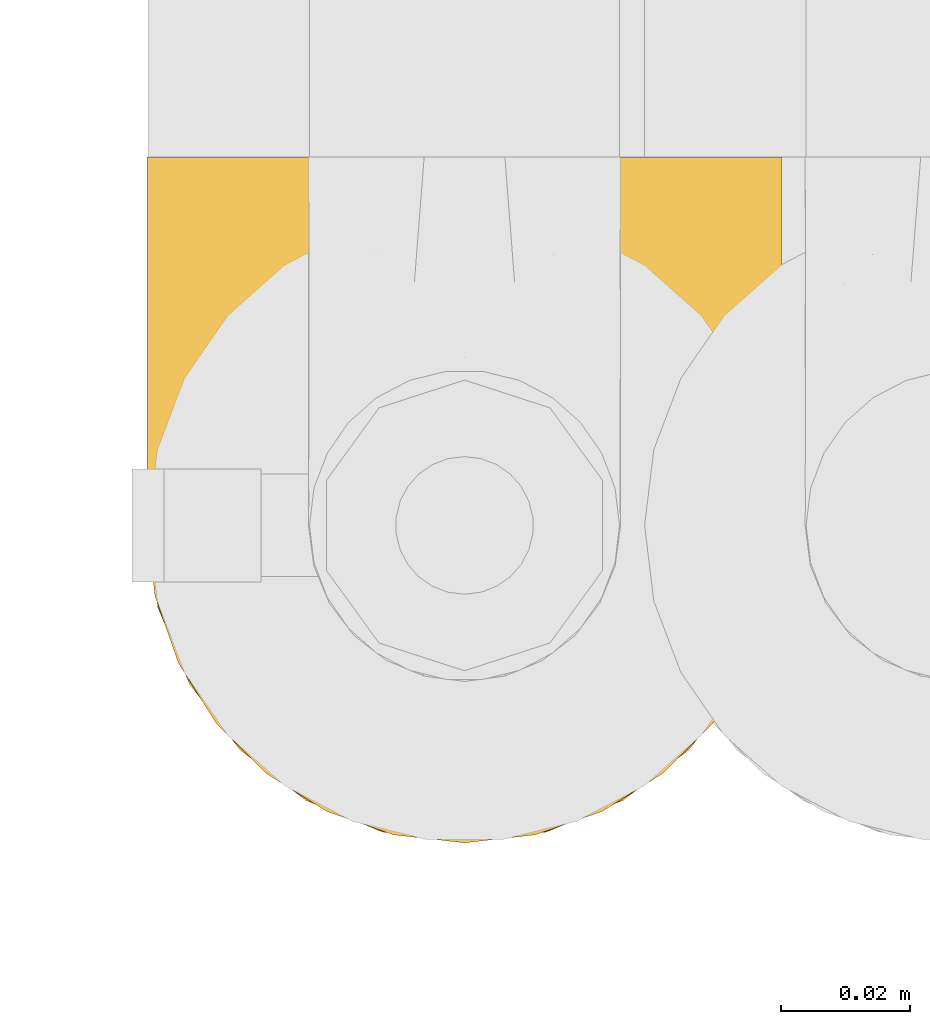
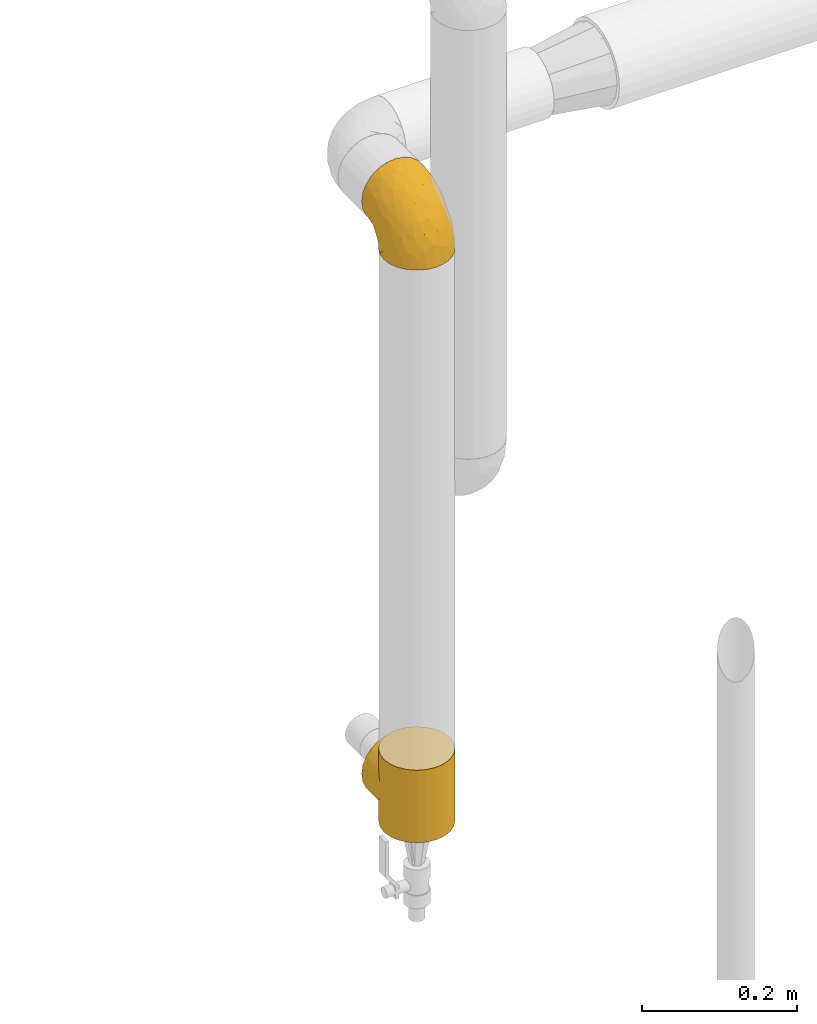
# One storey, part 410 of 827: 2 coverings.
"""IFC2X3 building model written with IfcOpenShell, lengths in millimetres."""

from ifc_helpers import new_model, entity, si_unit, converted_unit, derived_unit, direction, frame, origin, place, context, subcontext, project, spatial, faceted_brep, element, save


model = new_model("IFC2X3")

# Units and contexts
model_context = context("Model", 3, precision=0.01, world=origin(), true_north=direction((6.12303176911189e-17, 1.0)))
body_context = subcontext(model_context, "Body", "Model", "MODEL_VIEW")
ifc_project = project(units=[si_unit("LENGTHUNIT", "METRE", prefix="MILLI"), si_unit("AREAUNIT", "SQUARE_METRE"), si_unit("VOLUMEUNIT", "CUBIC_METRE"), converted_unit("PLANEANGLEUNIT", "DEGREE", entity("IfcRatioMeasure", 0.0174532925199433), si_unit("PLANEANGLEUNIT", "RADIAN"), dimensions=[0, 0, 0, 0, 0, 0, 0]), si_unit("MASSUNIT", "GRAM", prefix="KILO"), derived_unit("MASSDENSITYUNIT", [(si_unit("MASSUNIT", "GRAM", prefix="KILO"), 1), (si_unit("LENGTHUNIT", "METRE"), -3)]), derived_unit("MOMENTOFINERTIAUNIT", [(si_unit("LENGTHUNIT", "METRE"), 4)]), si_unit("TIMEUNIT", "SECOND"), si_unit("FREQUENCYUNIT", "HERTZ"), si_unit("THERMODYNAMICTEMPERATUREUNIT", "DEGREE_CELSIUS"), derived_unit("THERMALTRANSMITTANCEUNIT", [(si_unit("MASSUNIT", "GRAM", prefix="KILO"), 1), (si_unit("THERMODYNAMICTEMPERATUREUNIT", "KELVIN"), -1), (si_unit("TIMEUNIT", "SECOND"), -3)]), derived_unit("VOLUMETRICFLOWRATEUNIT", [(si_unit("LENGTHUNIT", "METRE"), 3), (si_unit("TIMEUNIT", "SECOND"), -1)]), derived_unit("MASSFLOWRATEUNIT", [(si_unit("MASSUNIT", "GRAM", prefix="KILO"), 1), (si_unit("TIMEUNIT", "SECOND"), -1)]), derived_unit("ROTATIONALFREQUENCYUNIT", [(si_unit("TIMEUNIT", "SECOND"), -1)]), si_unit("ELECTRICCURRENTUNIT", "AMPERE"), si_unit("ELECTRICVOLTAGEUNIT", "VOLT"), si_unit("POWERUNIT", "WATT"), si_unit("FORCEUNIT", "NEWTON", prefix="KILO"), si_unit("ILLUMINANCEUNIT", "LUX"), si_unit("LUMINOUSFLUXUNIT", "LUMEN"), si_unit("LUMINOUSINTENSITYUNIT", "CANDELA"), derived_unit("USERDEFINED", [(si_unit("MASSUNIT", "GRAM", prefix="KILO"), -1), (si_unit("LENGTHUNIT", "METRE"), -2), (si_unit("TIMEUNIT", "SECOND"), 3), (si_unit("LUMINOUSFLUXUNIT", "LUMEN"), 1)]), derived_unit("LINEARVELOCITYUNIT", [(si_unit("LENGTHUNIT", "METRE"), 1), (si_unit("TIMEUNIT", "SECOND"), -1)]), si_unit("PRESSUREUNIT", "PASCAL"), derived_unit("USERDEFINED", [(si_unit("LENGTHUNIT", "METRE"), -2), (si_unit("MASSUNIT", "GRAM", prefix="KILO"), 1), (si_unit("TIMEUNIT", "SECOND"), -2)]), derived_unit("LINEARFORCEUNIT", [(si_unit("MASSUNIT", "GRAM", prefix="KILO"), 1), (si_unit("LENGTHUNIT", "METRE"), 1), (si_unit("TIMEUNIT", "SECOND"), -2), (si_unit("LENGTHUNIT", "METRE"), -1)]), derived_unit("PLANARFORCEUNIT", [(si_unit("MASSUNIT", "GRAM", prefix="KILO"), 1), (si_unit("LENGTHUNIT", "METRE"), 1), (si_unit("TIMEUNIT", "SECOND"), -2), (si_unit("LENGTHUNIT", "METRE"), -2)])], contexts=[model_context])

# Site, building, storey
site_placement = place(None, origin())
site = spatial("IfcSite", under=ifc_project, at=site_placement, CompositionType="ELEMENT")
building_placement = place(site_placement, origin())
building = spatial("IfcBuilding", under=site, at=building_placement, CompositionType="ELEMENT")
storey_placement = place(building_placement, frame((0.0, 0.0, 28200.0)))
storey = spatial("IfcBuildingStorey", under=building, at=storey_placement, Name="08", CompositionType="ELEMENT", Elevation=28200.0)

# Coverings
covering_1_placement = place(storey_placement, frame((47533.55, 18915.48, 1241.4)))
element("IfcCovering", 1, at=covering_1_placement, inside=storey, Name=":ADSK_", ObjectType=":ADSK_", PredefinedType="INSULATION", context=body_context, shape_type="Brep", body=[
    faceted_brep([(99.9, 50.75, 1.6), (98.66, 39.8, 1.6), (95.02, 29.41, 1.6), (89.17, 20.09, 1.6), (81.38, 12.31, 1.6), (72.06, 6.46, 1.6), (61.68, 2.83, 1.6), (50.75, 1.6, 1.6), (39.8, 2.83, 1.6), (29.41, 6.47, 1.6), (20.09, 12.32, 1.6), (12.31, 20.11, 1.6), (6.46, 29.43, 1.6), (2.83, 39.81, 1.6), (1.6, 50.75, 1.6), (2.24, 56.45, 1.6), (2.83, 61.69, 1.6), (4.65, 66.88, 1.6), (6.47, 72.08, 1.6), (12.32, 81.4, 1.6), (20.11, 89.18, 1.6), (29.43, 95.03, 1.6), (39.81, 98.66, 1.6), (50.75, 99.9, 1.6), (61.69, 98.66, 1.6), (72.08, 95.02, 1.6), (81.4, 89.17, 1.6), (89.18, 81.38, 1.6), (95.03, 72.06, 1.6), (96.85, 66.87, 1.6), (98.66, 61.68, 1.6), (99.25, 56.45, 1.6), (99.57, 53.6, 1.6), (38.02, 107.75, 11.12), (26.17, 107.75, 16.03), (21.08, 107.75, 19.94), (15.99, 107.75, 23.84), (12.09, 107.75, 28.93), (8.18, 107.75, 34.02), (5.73, 107.75, 39.95), (3.27, 107.75, 45.87), (2.35, 107.75, 52.86), (1.97, 107.75, 55.73), (1.6, 107.75, 58.6), (3.27, 107.75, 71.32), (8.18, 107.75, 83.17), (15.99, 107.75, 93.35), (26.17, 107.75, 101.16), (38.02, 107.75, 106.07), (50.75, 107.75, 107.75), (63.47, 107.75, 106.07), (75.32, 107.75, 101.16), (85.5, 107.75, 93.35), (93.31, 107.75, 83.17), (98.22, 107.75, 71.32), (99.9, 107.75, 58.6), (99.14, 107.75, 52.86), (98.22, 107.75, 45.87), (95.77, 107.75, 39.95), (93.31, 107.75, 34.02), (89.4, 107.75, 28.93), (85.5, 107.75, 23.84), (80.41, 107.75, 19.94), (75.32, 107.75, 16.03), (63.47, 107.75, 11.12), (50.75, 107.75, 9.45), (59.31, 39.38, 81.82), (73.08, 49.75, 84.02), (63.72, 57.38, 93.05), (50.75, 74.94, 102.55), (58.64, 85.97, 104.83), (50.75, 95.66, 105.83), (76.74, 67.82, 91.87), (67.68, 83.09, 101.74), (78.92, 89.16, 97.07), (94.31, 37.01, 38.45), (98.76, 43.46, 22.17), (98.4, 51.79, 42.04), (94.57, 85.58, 77.69), (89.91, 62.84, 75.76), (96.32, 62.77, 62.11), (98.79, 88.17, 66.08), (99.9, 85.93, 54.26), (99.9, 91.42, 55.35), (99.9, 96.91, 56.44), (99.9, 99.62, 56.98), (99.9, 102.33, 57.52), (87.31, 82.57, 87.84), (95.61, 32.75, 19.41), (60.43, 13.79, 48.89), (65.24, 6.77, 26.34), (72.87, 16.46, 44.55), (99.9, 55.08, 23.41), (99.9, 58.17, 28.03), (99.9, 61.26, 32.65), (99.9, 64.35, 37.28), (99.9, 67.44, 41.9), (90.65, 24.18, 20.6), (63.14, 23.37, 63.36), (91.89, 49.76, 62.21), (75.25, 9.84, 19.94), (50.75, 3.51, 13.68), (82.18, 55.75, 80.85), (85.08, 42.34, 66.53), (76.93, 37.78, 71.06), (50.75, 21.87, 63.99), (50.75, 33.61, 75.73), (83.02, 17.1, 26.77), (99.9, 51.28, 4.31), (99.9, 51.82, 7.01), (99.9, 52.9, 12.43), (99.9, 53.99, 17.92), (87.13, 28.01, 43.43), (80.85, 28.99, 56.23), (99.17, 69.9, 54.97), (50.75, 6.79, 34.4), (99.9, 72.06, 44.99), (99.9, 76.69, 48.08), (99.9, 81.31, 51.17), (50.75, 45.35, 87.47), (67.61, 34.79, 74.55), (72.25, 25.72, 60.86), (50.75, 14.33, 49.19), (50.75, 60.15, 95.01), (98.69, 62.38, 10.27), (99.01, 100.57, 48.79), (98.79, 91.06, 45.16), (98.29, 97.66, 44.99), (68.51, 97.55, 6.17), (76.82, 93.65, 7.65), (98.54, 66.85, 21.59), (99.3, 61.93, 19.96), (83.57, 101.4, 21.0), (89.47, 100.07, 27.2), (75.76, 101.36, 14.83), (84.86, 95.94, 19.7), (75.89, 96.3, 10.93), (64.77, 101.98, 9.63), (90.83, 85.88, 19.97), (94.62, 78.88, 21.13), (90.37, 82.8, 14.14), (91.18, 102.58, 30.2), (88.65, 82.88, 8.12), (84.11, 88.57, 9.93), (91.75, 88.67, 24.62), (96.86, 69.08, 11.87), (50.75, 102.19, 7.15), (58.97, 100.06, 5.32), (98.37, 70.56, 26.68), (83.91, 91.07, 13.92), (97.52, 77.56, 30.67), (95.55, 96.59, 36.65), (98.76, 86.38, 42.89), (95.26, 91.79, 34.04), (98.04, 81.71, 36.6), (90.65, 94.11, 26.41), (93.51, 76.09, 10.07), (94.16, 76.91, 15.83), (99.1, 81.44, 41.99), (25.73, 101.37, 14.83), (10.84, 94.12, 26.4), (17.92, 101.41, 21.01), (16.64, 95.96, 19.71), (30.44, 96.22, 5.72), (2.95, 66.85, 21.6), (2.19, 61.94, 19.96), (1.6, 58.17, 28.03), (4.63, 69.1, 11.87), (17.39, 88.58, 9.93), (1.6, 96.91, 56.44), (1.6, 102.33, 57.52), (1.6, 105.04, 58.06), (12.86, 82.9, 8.13), (11.13, 82.82, 14.15), (3.2, 97.66, 44.99), (5.94, 96.59, 36.65), (12.02, 100.07, 27.21), (6.23, 91.79, 34.04), (10.31, 102.58, 30.2), (8.0, 76.13, 10.06), (7.34, 76.93, 15.83), (2.48, 100.57, 48.79), (2.73, 86.38, 42.89), (2.64, 90.86, 45.38), (1.6, 52.9, 12.43), (2.8, 62.39, 10.28), (36.71, 101.98, 9.64), (1.6, 91.42, 55.35), (1.6, 85.93, 54.26), (38.59, 99.49, 6.05), (1.6, 51.82, 7.01), (1.6, 52.36, 9.72), (1.6, 61.26, 32.65), (3.12, 70.56, 26.68), (17.59, 91.09, 13.92), (1.6, 64.35, 37.28), (3.98, 77.6, 30.66), (6.87, 78.89, 21.14), (3.45, 81.71, 36.59), (9.76, 88.69, 24.6), (1.6, 53.99, 17.92), (1.6, 55.08, 23.41), (25.62, 96.31, 10.93), (10.67, 85.9, 19.97), (2.39, 81.45, 41.99), (1.6, 76.69, 48.08), (1.6, 81.31, 51.17), (1.6, 72.06, 44.99), (1.6, 67.44, 41.9), (2.4, 69.6, 55.26), (42.85, 85.97, 104.83), (14.18, 82.57, 87.84), (11.56, 63.16, 75.91), (19.27, 55.81, 80.84), (24.75, 67.81, 91.87), (28.37, 49.73, 83.98), (5.95, 32.55, 19.16), (2.79, 43.23, 22.37), (2.71, 88.17, 66.08), (37.78, 57.38, 93.05), (33.81, 83.08, 101.74), (22.57, 89.16, 97.07), (6.92, 85.58, 77.69), (28.61, 16.46, 44.55), (36.24, 6.77, 26.34), (41.05, 13.8, 48.9), (24.55, 37.71, 70.99), (33.88, 34.8, 74.55), (7.11, 36.83, 37.8), (42.18, 39.38, 81.82), (18.46, 17.12, 26.77), (10.84, 24.19, 20.6), (20.69, 28.89, 56.15), (29.27, 25.69, 60.85), (3.1, 51.77, 42.06), (9.18, 45.66, 57.03), (38.38, 23.39, 63.4), (26.23, 9.85, 19.94), (14.34, 28.11, 43.59), (5.46, 62.27, 62.61), (16.39, 42.35, 66.52)], [[[0, 1, 2, 3, 4, 5, 6, 7, 8, 9, 10, 11, 12, 13, 14, 15, 16, 17, 18, 19, 20, 21, 22, 23, 24, 25, 26, 27, 28, 29, 30, 31, 32]], [[33, 34, 35, 36, 37, 38, 39, 40, 41, 42, 43, 44, 45, 46, 47, 48, 49, 50, 51, 52, 53, 54, 55, 56, 57, 58, 59, 60, 61, 62, 63, 64, 65]], [[66, 67, 68]], [[69, 70, 71]], [[68, 72, 73]], [[73, 72, 74]], [[75, 76, 77]], [[78, 79, 80]], [[51, 50, 73]], [[81, 82, 83, 84, 85, 86, 55]], [[52, 87, 53]], [[74, 52, 51]], [[2, 1, 88]], [[89, 90, 91]], [[77, 92, 93, 94, 95, 96]], [[55, 54, 81]], [[78, 53, 87]], [[5, 90, 6]], [[88, 76, 75]], [[97, 3, 2]], [[89, 91, 98]], [[99, 80, 79]], [[90, 5, 100]], [[74, 87, 52]], [[100, 5, 4]], [[90, 101, 6]], [[79, 102, 103]], [[102, 67, 104]], [[105, 98, 106]], [[107, 4, 3]], [[76, 0, 108, 109, 110, 111, 92]], [[107, 112, 113]], [[114, 77, 96]], [[89, 115, 90]], [[114, 96, 116, 117, 118, 82]], [[75, 97, 88]], [[119, 66, 68]], [[50, 71, 70]], [[100, 91, 90]], [[99, 77, 80]], [[102, 104, 103]], [[97, 107, 3]], [[80, 81, 78]], [[107, 97, 112]], [[68, 73, 70]], [[66, 98, 120]], [[78, 81, 54]], [[114, 81, 80]], [[53, 78, 54]], [[78, 87, 79]], [[102, 87, 72]], [[79, 103, 99]], [[4, 107, 100]], [[91, 100, 107]], [[88, 97, 2]], [[112, 97, 75]], [[99, 112, 75]], [[103, 104, 113]], [[91, 121, 98]], [[89, 105, 122, 115]], [[101, 90, 115]], [[101, 7, 6]], [[88, 1, 76]], [[0, 76, 1]], [[92, 77, 76]], [[73, 74, 51]], [[87, 74, 72]], [[81, 114, 82]], [[77, 114, 80]], [[87, 102, 79]], [[67, 102, 72]], [[68, 67, 72]], [[67, 120, 104]], [[120, 121, 104]], [[104, 121, 113]], [[121, 120, 98]], [[91, 107, 113]], [[91, 113, 121]], [[103, 113, 112]], [[106, 98, 66]], [[105, 89, 98]], [[106, 66, 119]], [[67, 66, 120]], [[68, 69, 123, 119]], [[50, 49, 71]], [[50, 70, 73]], [[112, 99, 103]], [[77, 99, 75]], [[69, 68, 70]], [[29, 124, 110]], [[84, 83, 125]], [[126, 82, 118]], [[59, 58, 127]], [[25, 128, 129]], [[130, 93, 131]], [[132, 62, 133]], [[134, 135, 136]], [[137, 65, 64]], [[64, 134, 137]], [[138, 139, 140]], [[111, 110, 124, 92]], [[134, 136, 137]], [[134, 64, 63]], [[141, 61, 60]], [[125, 58, 57]], [[142, 143, 140]], [[142, 26, 143]], [[127, 83, 82]], [[28, 124, 29]], [[108, 0, 32, 31, 30, 110, 109]], [[30, 29, 110]], [[135, 144, 138]], [[28, 145, 124]], [[57, 56, 55, 86, 85, 84]], [[146, 147, 23]], [[24, 23, 147]], [[25, 143, 26]], [[95, 94, 148]], [[24, 128, 25]], [[149, 138, 143]], [[124, 145, 131]], [[127, 58, 125]], [[150, 148, 139]], [[127, 126, 151]], [[151, 59, 127]], [[152, 151, 126]], [[153, 154, 155]], [[153, 133, 141]], [[145, 28, 27]], [[142, 156, 27]], [[157, 148, 130]], [[61, 133, 62]], [[134, 132, 135]], [[147, 128, 24]], [[65, 137, 146]], [[146, 137, 147]], [[128, 137, 136]], [[137, 128, 147]], [[128, 136, 129]], [[149, 129, 136]], [[25, 129, 143]], [[158, 152, 117]], [[152, 118, 117]], [[153, 151, 152]], [[158, 116, 154]], [[144, 150, 138]], [[153, 152, 158]], [[133, 153, 155]], [[133, 155, 132]], [[60, 151, 141]], [[135, 132, 155]], [[134, 63, 132]], [[144, 135, 155]], [[135, 138, 149]], [[155, 154, 144]], [[150, 154, 96]], [[154, 150, 144]], [[148, 94, 130]], [[82, 126, 127]], [[118, 152, 126]], [[150, 96, 95]], [[139, 148, 157]], [[150, 95, 148]], [[93, 92, 131]], [[130, 145, 156]], [[130, 94, 93]], [[84, 125, 57]], [[127, 125, 83]], [[140, 139, 157]], [[150, 139, 138]], [[140, 157, 142]], [[138, 140, 143]], [[156, 142, 157]], [[27, 26, 142]], [[130, 156, 157]], [[145, 27, 156]], [[132, 63, 62]], [[124, 131, 92]], [[130, 131, 145]], [[129, 149, 143]], [[135, 149, 136]], [[141, 133, 61]], [[60, 59, 151]], [[141, 151, 153]], [[116, 96, 154]], [[153, 158, 154]], [[158, 117, 116]], [[34, 33, 159]], [[160, 161, 162]], [[22, 21, 163]], [[164, 165, 166]], [[19, 18, 167]], [[168, 21, 20]], [[42, 41, 40, 169, 170, 171, 43]], [[172, 173, 168]], [[174, 38, 175]], [[176, 177, 178]], [[179, 164, 180]], [[40, 181, 169]], [[182, 183, 175]], [[17, 184, 185]], [[65, 146, 186]], [[187, 174, 188]], [[23, 22, 189]], [[174, 39, 38]], [[15, 14, 190, 191, 184, 16]], [[181, 40, 39]], [[192, 193, 164]], [[194, 163, 168]], [[33, 186, 159]], [[180, 173, 172]], [[195, 196, 193]], [[18, 185, 167]], [[173, 180, 197]], [[198, 199, 196]], [[200, 201, 185, 184]], [[184, 17, 16]], [[18, 17, 185]], [[202, 159, 186]], [[194, 168, 203]], [[189, 163, 202]], [[204, 205, 182]], [[187, 181, 174]], [[160, 177, 176]], [[206, 183, 182]], [[206, 182, 205]], [[201, 165, 185]], [[165, 164, 167]], [[172, 179, 180]], [[202, 194, 162]], [[176, 161, 160]], [[65, 186, 33]], [[163, 189, 22]], [[175, 177, 182]], [[174, 183, 188]], [[177, 198, 204]], [[199, 160, 162]], [[198, 207, 204]], [[175, 38, 37]], [[198, 177, 160]], [[178, 177, 175]], [[176, 35, 161]], [[34, 159, 161]], [[162, 161, 159]], [[202, 162, 159]], [[199, 162, 203]], [[196, 199, 203]], [[198, 160, 199]], [[193, 197, 180]], [[208, 198, 196]], [[188, 183, 206]], [[175, 183, 174]], [[193, 192, 195]], [[195, 208, 196]], [[197, 196, 203]], [[180, 164, 193]], [[168, 163, 21]], [[166, 165, 201]], [[166, 192, 164]], [[189, 202, 186]], [[186, 146, 189]], [[23, 189, 146]], [[174, 181, 39]], [[169, 181, 187]], [[196, 197, 193]], [[173, 203, 168]], [[203, 173, 197]], [[172, 168, 20]], [[20, 19, 172]], [[179, 172, 19]], [[19, 167, 179]], [[164, 179, 167]], [[35, 176, 36]], [[35, 34, 161]], [[185, 165, 167]], [[162, 194, 203]], [[163, 194, 202]], [[176, 178, 36]], [[37, 36, 178]], [[175, 37, 178]], [[177, 204, 182]], [[207, 198, 208]], [[207, 205, 204]], [[209, 188, 206, 205, 207, 208]], [[48, 210, 71]], [[211, 212, 213]], [[214, 213, 215]], [[216, 217, 13]], [[218, 43, 171, 170, 169, 187, 188]], [[219, 220, 214]], [[47, 46, 221]], [[210, 48, 220]], [[211, 222, 212]], [[222, 45, 44]], [[221, 220, 47]], [[47, 220, 48]], [[221, 211, 214]], [[223, 224, 225]], [[211, 46, 45]], [[226, 227, 215]], [[43, 218, 44]], [[217, 216, 228]], [[219, 215, 229]], [[14, 13, 217]], [[224, 9, 8]], [[10, 230, 11]], [[11, 231, 12]], [[232, 223, 233]], [[234, 208, 195, 192, 166, 201]], [[235, 234, 228]], [[222, 44, 218]], [[106, 229, 236]], [[224, 237, 9]], [[231, 238, 228]], [[9, 237, 10]], [[115, 224, 101]], [[239, 234, 235]], [[231, 11, 230]], [[223, 230, 237]], [[224, 8, 101]], [[223, 236, 233]], [[225, 115, 122, 105]], [[216, 12, 231]], [[209, 234, 239]], [[210, 219, 69]], [[219, 214, 215]], [[229, 119, 219]], [[209, 218, 188]], [[239, 212, 222]], [[239, 222, 218]], [[45, 222, 211]], [[235, 212, 239]], [[213, 212, 240]], [[223, 237, 224]], [[230, 10, 237]], [[238, 231, 230]], [[216, 231, 228]], [[232, 230, 223]], [[235, 238, 240]], [[115, 225, 224]], [[233, 236, 227]], [[8, 7, 101]], [[234, 209, 208]], [[218, 209, 239]], [[217, 228, 234]], [[13, 12, 216]], [[234, 201, 217]], [[217, 201, 200, 184, 191, 190, 14]], [[211, 221, 46]], [[220, 221, 214]], [[71, 210, 69]], [[71, 49, 48]], [[219, 210, 220]], [[226, 215, 213]], [[211, 213, 214]], [[226, 213, 240]], [[215, 227, 229]], [[232, 240, 238]], [[233, 227, 226]], [[232, 233, 226]], [[236, 223, 225]], [[240, 232, 226]], [[232, 238, 230]], [[225, 105, 236]], [[236, 105, 106]], [[236, 229, 227]], [[123, 69, 219, 119]], [[106, 119, 229]], [[238, 235, 228]], [[212, 235, 240]]]),
])
covering_2_placement = place(storey_placement, frame((47533.55, 18915.48, 343.0)))
element("IfcCovering", 2, at=covering_2_placement, inside=storey, Name=":ADSK_", ObjectType=":ADSK_", PredefinedType="INSULATION", context=body_context, shape_type="Brep", body=[
    faceted_brep([(53.93, 99.48, 114.0), (57.11, 99.06, 114.0), (55.89, 99.35, 105.6), (61.04, 98.8, 105.06), (60.29, 98.64, 114.0), (63.47, 98.22, 114.0), (70.52, 95.74, 102.0), (69.39, 95.77, 114.0), (75.32, 93.31, 114.0), (65.78, 97.27, 103.53), (78.69, 91.18, 97.43), (80.41, 89.4, 114.0), (85.44, 85.56, 91.82), (74.6, 93.46, 99.71), (53.32, 99.62, 105.88), (50.75, 99.9, 114.0), (85.5, 85.5, 114.0), (90.79, 79.24, 85.5), (93.31, 75.32, 114.0), (94.84, 72.45, 78.71), (98.22, 63.47, 114.0), (99.34, 58.1, 64.35), (99.9, 50.75, 114.0), (50.75, 99.9, 106.15), (53.32, 99.62, 8.12), (50.75, 99.9, 0.0), (50.75, 99.9, 7.85), (97.67, 65.36, 71.62), (99.9, 50.75, 57.0), (99.34, 58.1, 49.65), (99.9, 50.75, 0.0), (2.04, 57.36, 63.62), (1.6, 50.75, 114.0), (3.27, 63.47, 114.0), (8.18, 75.32, 114.0), (5.67, 70.35, 76.6), (13.2, 82.47, 88.72), (15.99, 85.5, 114.0), (8.92, 76.57, 82.82), (1.6, 50.75, 57.0), (2.04, 57.36, 50.38), (1.6, 50.75, 0.0), (46.1, 99.45, 105.71), (44.38, 99.06, 114.0), (47.57, 99.48, 114.0), (3.39, 63.92, 70.17), (47.57, 99.48, 0.0), (18.57, 87.9, 94.16), (26.17, 93.31, 114.0), (32.1, 95.77, 114.0), (38.02, 98.22, 114.0), (37.11, 97.75, 104.0), (41.45, 99.01, 105.26), (25.1, 92.68, 98.93), (32.77, 96.49, 102.75), (41.2, 98.64, 114.0), (75.32, 8.18, 0.0), (63.47, 3.27, 0.0), (50.75, 1.6, 0.0), (38.02, 3.27, 0.0), (26.17, 8.18, 0.0), (15.99, 15.99, 0.0), (8.18, 26.17, 0.0), (3.27, 38.02, 0.0), (3.27, 63.47, 0.0), (8.18, 75.32, 0.0), (15.99, 85.5, 0.0), (26.17, 93.31, 0.0), (32.1, 95.77, 0.0), (38.02, 98.22, 0.0), (41.2, 98.64, 0.0), (44.38, 99.06, 0.0), (53.93, 99.48, 0.0), (57.11, 99.06, 0.0), (60.29, 98.64, 0.0), (63.47, 98.22, 0.0), (69.39, 95.77, 0.0), (75.32, 93.31, 0.0), (80.41, 89.4, 0.0), (85.5, 85.5, 0.0), (93.31, 75.32, 0.0), (98.22, 63.47, 0.0), (98.22, 38.02, 0.0), (93.31, 26.17, 0.0), (85.5, 15.99, 0.0), (3.27, 38.02, 114.0), (8.18, 26.17, 114.0), (15.99, 15.99, 114.0), (26.17, 8.18, 114.0), (38.02, 3.27, 114.0), (50.75, 1.6, 114.0), (63.47, 3.27, 114.0), (75.32, 8.18, 114.0), (85.5, 15.99, 114.0), (93.31, 26.17, 114.0), (98.22, 38.02, 114.0), (3.39, 63.92, 43.83), (5.67, 70.35, 37.4), (46.1, 99.45, 8.29), (8.92, 76.57, 31.18), (13.2, 82.47, 25.28), (41.45, 99.01, 8.74), (18.57, 87.9, 19.84), (25.1, 92.68, 15.07), (37.11, 97.75, 10.0), (32.77, 96.49, 11.25), (70.52, 95.74, 12.0), (65.78, 97.27, 10.47), (78.69, 91.18, 16.57), (61.04, 98.8, 8.94), (85.44, 85.56, 22.18), (74.6, 93.46, 14.29), (55.89, 99.35, 8.4), (94.84, 72.45, 35.29), (97.67, 65.36, 42.38), (90.79, 79.24, 28.5), (3.27, 107.75, 69.72), (8.18, 107.75, 81.57), (15.99, 107.75, 91.75), (26.17, 107.75, 99.57), (32.1, 107.75, 102.02), (38.02, 107.75, 104.48), (41.2, 107.75, 104.89), (44.38, 107.75, 105.31), (47.57, 107.75, 105.73), (50.75, 107.75, 106.15), (53.93, 107.75, 105.73), (57.11, 107.75, 105.31), (60.29, 107.75, 104.89), (63.47, 107.75, 104.48), (69.39, 107.75, 102.02), (75.32, 107.75, 99.57), (80.41, 107.75, 95.66), (85.5, 107.75, 91.75), (93.31, 107.75, 81.57), (98.22, 107.75, 69.72), (99.9, 107.75, 57.0), (98.22, 107.75, 44.28), (93.31, 107.75, 32.42), (85.5, 107.75, 22.25), (80.41, 107.75, 18.34), (75.32, 107.75, 14.43), (69.39, 107.75, 11.98), (63.47, 107.75, 9.52), (60.29, 107.75, 9.11), (57.11, 107.75, 8.69), (53.93, 107.75, 8.27), (50.75, 107.75, 7.85), (47.57, 107.75, 8.27), (44.38, 107.75, 8.69), (41.2, 107.75, 9.11), (38.02, 107.75, 9.52), (32.1, 107.75, 11.98), (26.17, 107.75, 14.43), (15.99, 107.75, 22.25), (8.18, 107.75, 32.42), (3.27, 107.75, 44.28), (1.6, 107.75, 57.0)], [[[0, 1, 2]], [[3, 1, 4, 5]], [[6, 7, 8]], [[9, 7, 6]], [[9, 3, 5]], [[10, 8, 11]], [[12, 10, 11]], [[6, 8, 10, 13]], [[14, 15, 0]], [[11, 16, 12]], [[17, 16, 18]], [[19, 18, 20]], [[21, 20, 22]], [[19, 17, 18]], [[15, 14, 23]], [[24, 25, 26]], [[21, 27, 20]], [[28, 21, 22]], [[29, 28, 30]], [[1, 3, 2]], [[19, 20, 27]], [[7, 9, 5]], [[16, 17, 12]], [[0, 2, 14]], [[31, 32, 33]], [[33, 34, 35]], [[36, 34, 37]], [[36, 38, 34]], [[31, 39, 32]], [[39, 40, 41]], [[42, 43, 44]], [[35, 45, 33]], [[38, 35, 34]], [[31, 33, 45]], [[23, 44, 15]], [[46, 26, 25]], [[47, 37, 48]], [[49, 50, 51]], [[23, 42, 44]], [[50, 52, 51]], [[53, 47, 48]], [[54, 48, 49]], [[54, 49, 51]], [[52, 43, 42]], [[52, 50, 55, 43]], [[53, 48, 54]], [[37, 47, 36]], [[56, 57, 58, 59, 60, 61, 62, 63, 41, 64, 65, 66, 67, 68, 69, 70, 71, 46, 25, 72, 73, 74, 75, 76, 77, 78, 79, 80, 81, 30, 82, 83, 84]], [[85, 86, 87, 88, 89, 90, 91, 92, 93, 94, 95, 22, 20, 18, 16, 11, 8, 7, 5, 4, 1, 0, 15, 44, 43, 55, 50, 49, 48, 37, 34, 33, 32]], [[88, 87, 61, 60]], [[58, 90, 89, 59]], [[89, 88, 60, 59]], [[62, 86, 85, 63]], [[32, 39, 41, 63, 85]], [[61, 87, 86, 62]], [[96, 97, 64]], [[26, 46, 98]], [[40, 96, 64]], [[41, 40, 64]], [[65, 99, 100]], [[65, 64, 97]], [[71, 101, 98]], [[65, 100, 66]], [[99, 65, 97]], [[102, 103, 67]], [[104, 68, 105]], [[104, 101, 69]], [[68, 104, 69]], [[103, 105, 67]], [[66, 102, 67]], [[101, 71, 70, 69]], [[68, 67, 105]], [[98, 46, 71]], [[102, 66, 100]], [[106, 76, 107]], [[106, 77, 76]], [[77, 108, 78]], [[109, 75, 74, 73]], [[110, 78, 108]], [[111, 108, 77, 106]], [[25, 24, 72]], [[109, 73, 112]], [[72, 24, 112]], [[76, 75, 107]], [[110, 79, 78]], [[75, 109, 107]], [[113, 114, 81]], [[114, 29, 81]], [[79, 115, 80]], [[115, 79, 110]], [[113, 80, 115]], [[113, 81, 80]], [[29, 30, 81]], [[112, 73, 72]], [[28, 22, 95, 82, 30]], [[82, 95, 94, 83]], [[94, 93, 84, 83]], [[84, 93, 92, 56]], [[56, 92, 91, 57]], [[57, 91, 90, 58]], [[116, 117, 118, 119, 120, 121, 122, 123, 124, 125, 126, 127, 128, 129, 130, 131, 132, 133, 134, 135, 136, 137, 138, 139, 140, 141, 142, 143, 144, 145, 146, 147, 148, 149, 150, 151, 152, 153, 154, 155, 156, 157]], [[52, 123, 122, 121]], [[119, 118, 47]], [[23, 124, 42]], [[54, 120, 119]], [[124, 23, 125]], [[124, 123, 42]], [[120, 51, 121]], [[53, 54, 119]], [[47, 53, 119]], [[51, 120, 54]], [[52, 121, 51]], [[118, 36, 47]], [[38, 36, 117]], [[117, 36, 118]], [[35, 117, 116]], [[31, 116, 157]], [[35, 38, 117]], [[31, 45, 116]], [[39, 31, 157]], [[35, 116, 45]], [[123, 52, 42]], [[40, 157, 156]], [[156, 155, 97]], [[100, 155, 154]], [[100, 99, 155]], [[40, 39, 157]], [[98, 149, 148]], [[97, 96, 156]], [[99, 97, 155]], [[40, 156, 96]], [[26, 148, 147]], [[102, 154, 153]], [[152, 151, 104]], [[26, 98, 148]], [[151, 101, 104]], [[103, 102, 153]], [[105, 153, 152]], [[105, 152, 104]], [[101, 149, 98]], [[101, 151, 150, 149]], [[103, 153, 105]], [[154, 102, 100]], [[146, 145, 112]], [[109, 145, 144, 143]], [[106, 142, 141]], [[107, 142, 106]], [[107, 109, 143]], [[108, 141, 140]], [[110, 108, 140]], [[106, 141, 108, 111]], [[24, 147, 146]], [[140, 139, 110]], [[115, 139, 138]], [[113, 138, 137]], [[29, 137, 136]], [[113, 115, 138]], [[147, 24, 26]], [[29, 114, 137]], [[28, 29, 136]], [[145, 109, 112]], [[113, 137, 114]], [[142, 107, 143]], [[139, 115, 110]], [[146, 112, 24]], [[21, 136, 135]], [[135, 134, 19]], [[17, 134, 133]], [[17, 19, 134]], [[14, 125, 23]], [[21, 28, 136]], [[3, 129, 128, 127]], [[19, 27, 135]], [[21, 135, 27]], [[2, 127, 126]], [[131, 6, 13, 10]], [[125, 14, 126]], [[10, 132, 131]], [[130, 129, 9]], [[14, 2, 126]], [[12, 133, 132]], [[12, 132, 10]], [[6, 130, 9]], [[3, 127, 2]], [[6, 131, 130]], [[129, 3, 9]], [[133, 12, 17]]]),
])

save(model, "model.ifc")
